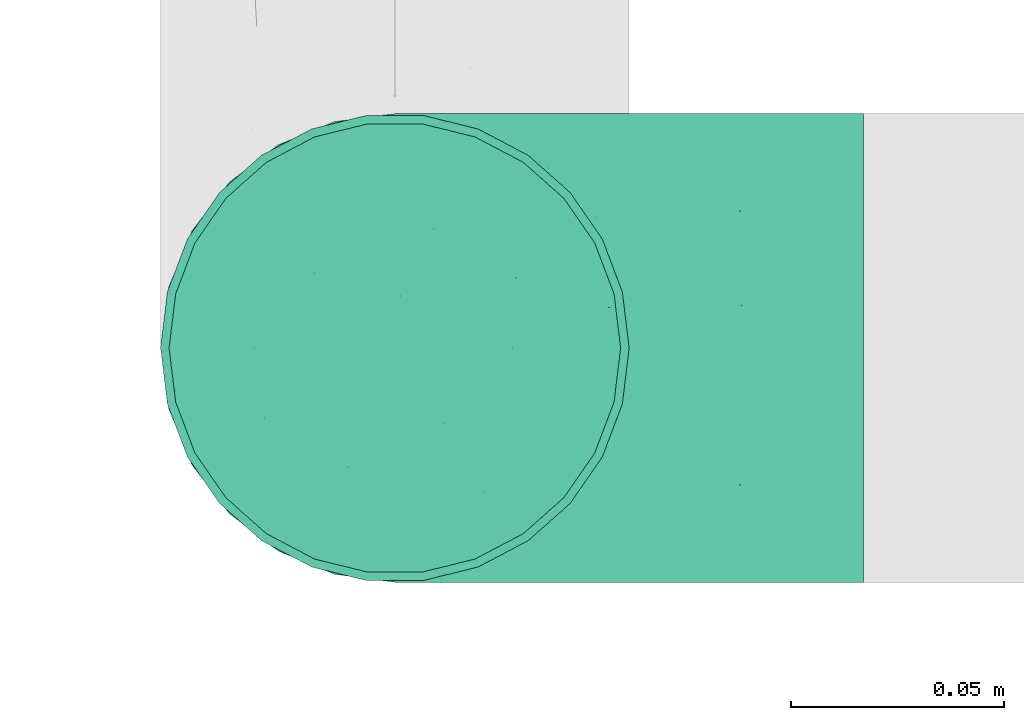
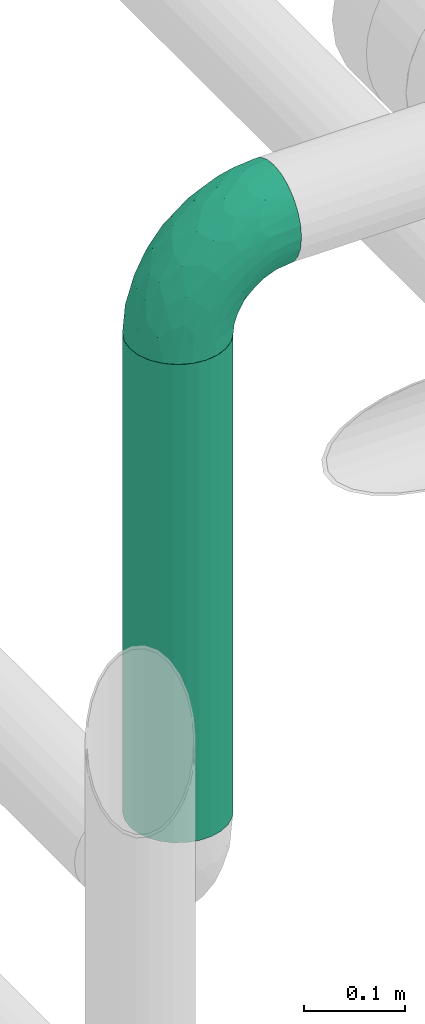
# One storey, part 41 of 91: 1 flow fitting, 1 flow segment.
"""IFC2X3 building model written with IfcOpenShell, lengths in millimetres."""

from ifc_helpers import new_model, entity, si_unit, converted_unit, derived_unit, direction, frame, origin_with_axes, origin_2d_with_axis, place, context, subcontext, project, spatial, hollow_circle, extrude, open_shell, surface_model, source, transform, mapped, material, layer, layer_set, layer_usage, type_object, element, save


model = new_model("IFC2X3")

# Units and contexts
model_context = context("Model", 3, precision=1e-05, world=origin_with_axes(), true_north=direction((0.0, 1.0)))
body_context = subcontext(model_context, "Body", "Model", "MODEL_VIEW")
ifc_project = project(units=[si_unit("AREAUNIT", "SQUARE_METRE"), si_unit("VOLUMEUNIT", "CUBIC_METRE", prefix="DECI"), si_unit("TIMEUNIT", "SECOND"), si_unit("THERMODYNAMICTEMPERATUREUNIT", "DEGREE_CELSIUS"), si_unit("PRESSUREUNIT", "PASCAL"), si_unit("MASSUNIT", "GRAM", prefix="KILO"), si_unit("LENGTHUNIT", "METRE", prefix="MILLI"), si_unit("POWERUNIT", "WATT"), si_unit("ELECTRICCURRENTUNIT", "AMPERE"), si_unit("ELECTRICVOLTAGEUNIT", "VOLT"), derived_unit("VOLUMETRICFLOWRATEUNIT", [(si_unit("VOLUMEUNIT", "CUBIC_METRE", prefix="DECI"), 1), (si_unit("TIMEUNIT", "SECOND"), -1)]), derived_unit("LINEARVELOCITYUNIT", [(si_unit("LENGTHUNIT", "METRE"), 1), (si_unit("TIMEUNIT", "SECOND"), -1)]), derived_unit("MASSDENSITYUNIT", [(si_unit("MASSUNIT", "GRAM", prefix="KILO"), 1), (si_unit("VOLUMEUNIT", "CUBIC_METRE"), -1)]), converted_unit("PLANEANGLEUNIT", "DEGREE", entity("IfcRatioMeasure", 0.01745), si_unit("PLANEANGLEUNIT", "RADIAN"), dimensions=[0, 0, 0, 0, 0, 0, 0])], contexts=[model_context])

# Site, building, storey
site_placement = place(None, origin_with_axes())
site = spatial("IfcSite", under=ifc_project, at=site_placement, CompositionType="ELEMENT")
building_placement = place(site_placement, origin_with_axes())
building = spatial("IfcBuilding", under=site, at=building_placement, Name="mc-building", CompositionType="ELEMENT")
storey_placement = place(building_placement, frame((0.0, 0.0, 8700.0), z_axis=(0.0, 0.0, 1.0), x_axis=(1.0, 0.0, 0.0)))
storey = spatial("IfcBuildingStorey", under=building, at=storey_placement, CompositionType="ELEMENT", Elevation=8700.0)

# Flow segment
ifc_material = material(Name="FZ1")
ifc_layer = layer(ifc_material, 0.0)
ifc_layer_set = layer_set([ifc_layer], Name="FZ1")
ifc_layer_usage = layer_usage(ifc_layer_set, "AXIS1", "POSITIVE", 0.0)
duct_segment_type = type_object("IfcDuctSegmentType", PredefinedType="RIGIDSEGMENT")
shared_shape_1 = source(origin_with_axes(), body_context, "Body", "SweptSolid", [
    extrude(hollow_circle(Radius=55.0, WallThickness=2.0, at=origin_2d_with_axis()), frame((0.0, 0.0, 0.0), z_axis=(1.0, 0.0, 0.0), x_axis=(0.0, 1.0, 0.0)), (0.0, 0.0, 1.0), 579.3),
])
flow_segment_placement = place(storey_placement, frame((7969.21808, 10596.38741, 1104.30701), z_axis=(0.0, 1.0, 0.0), x_axis=(0.0, 0.0, -1.0)))
element("IfcFlowSegment", 1, at=flow_segment_placement, inside=storey, type_object=duct_segment_type, material=ifc_layer_usage, context=body_context, shape_type="MappedRepresentation", body=[
    mapped(shared_shape_1, transform((0.0, 0.0, 0.0), scale=1.0)),
])

# Flow fitting
duct_fitting_type = type_object("IfcDuctFittingType", Name="BU", PredefinedType="BEND")
shared_shape_2 = source(origin_with_axes(), body_context, "Body", "SurfaceModel", [
    surface_model("IfcShellBasedSurfaceModel", [(-110.0, 0.0, -55.0), (-110.0, -14.23505, -53.12592), (-110.0, 14.23505, -53.12592), (-110.0, 53.12592, 14.23505), (-110.0, 27.5, -47.63139), (-110.0, 38.89087, -38.89087), (-110.0, -55.0, 0.0), (-110.0, -53.12592, 14.23505), (-110.0, -38.89087, -38.89087), (-110.0, -27.5, -47.63139), (-110.0, -53.12592, -14.23505), (-110.0, -47.63139, -27.5), (-110.0, -14.23505, 53.12592), (-110.0, 14.23505, 53.12592), (-110.0, 27.5, 47.63139), (-110.0, -47.63139, 27.5), (-110.0, -38.89087, 38.89087), (-110.0, -27.5, 47.63139), (-110.0, 0.0, 55.0), (-110.0, 55.0, 0.0), (-110.0, 53.12592, -14.23505), (-110.0, 47.63139, -27.5), (-110.0, 47.63139, 27.5), (-110.0, 38.89087, 38.89087), (-14.23505, 110.0, -53.12592), (-55.0, 110.0, 0.0), (0.0, 110.0, -55.0), (-27.5, 110.0, -47.63139), (-38.89087, 110.0, -38.89087), (-47.63139, 110.0, -27.5), (38.89087, 110.0, -38.89087), (53.12592, 110.0, 14.23505), (27.5, 110.0, -47.63139), (14.23505, 110.0, -53.12592), (47.63139, 110.0, -27.5), (53.12592, 110.0, -14.23505), (55.0, 110.0, 0.0), (-53.12592, 110.0, -14.23505), (-53.12592, 110.0, 14.23505), (-47.63139, 110.0, 27.5), (-38.89087, 110.0, 38.89087), (-27.5, 110.0, 47.63139), (0.0, 110.0, 55.0), (-14.23505, 110.0, 53.12592), (38.89087, 110.0, 38.89087), (47.63139, 110.0, 27.5), (27.5, 110.0, 47.63139), (14.23505, 110.0, 53.12592), (-64.21732, 48.68956, 43.63444), (-76.6405, 38.18013, 45.55988), (-60.44912, 32.56953, 51.94617), (-76.00813, 5.38378, 55.0), (-90.15553, 11.94394, 54.09138), (-78.5998, 26.77405, 50.81338), (-70.18771, 18.55163, 54.03432), (-75.55424, 54.2118, 32.41257), (-93.27622, 45.77614, 33.48188), (-96.12334, 22.13664, 50.81337), (-21.00813, 45.34362, 55.0), (-18.36258, 70.48427, 54.04484), (-32.04182, 59.64019, 52.24446), (-63.88653, 74.77858, 17.99134), (-74.66383, 63.08407, 19.92123), (-63.60674, 66.07878, 29.97482), (-99.597, 52.72185, 18.52927), (-93.11138, 56.59448, 10.50359), (-98.21577, 57.34403, 0.0), (-53.42855, 92.60092, 21.04759), (-88.54852, 54.8376, 21.04759), (-11.86161, 90.23965, 54.10313), (-5.38378, 76.00813, 55.0), (-57.34403, 98.21577, 0.0), (-56.64619, 93.12774, 10.22088), (-45.34362, 21.00813, 55.0), (-44.60838, 44.60838, 52.13415), (-92.68484, 35.46673, 43.63443), (-22.25266, 95.40765, 50.81337), (-35.97783, 90.61597, 43.63443), (-43.70931, 69.58671, 44.47149), (-27.23711, 77.39884, 50.81337), (-57.2828, 79.3123, 24.9774), (-58.67786, 84.31125, 16.04456), (-82.93277, 60.36161, 12.91784), (-49.88337, 54.51816, 47.224), (-74.57753, 66.83759, 9.55742), (-45.35812, 94.97281, 33.48188), (-59.18663, 88.95241, 0.0), (-51.517, 78.6292, 33.48188), (-65.14788, 80.03077, 0.0), (-56.45322, 62.06476, 39.63545), (-88.95241, 59.18663, 0.0), (-71.10913, 71.10913, 0.0), (-80.03077, 65.14788, 0.0), (-94.9309, 45.36788, -33.48188), (-93.11358, 56.60141, -10.46614), (-99.64997, 52.79499, -18.30015), (-90.20425, 36.08686, -43.63443), (-79.99933, 46.56772, -37.92748), (-76.00813, 5.38378, -55.0), (-72.75364, 19.68651, -53.60527), (-45.34362, 21.00813, -55.0), (-21.91957, 65.12078, -53.85897), (-5.38378, 76.00813, -55.0), (-21.00813, 45.34362, -55.0), (-35.41876, 92.89265, -43.63443), (-91.10309, 11.02766, -54.21832), (-45.77614, 93.27622, -33.48188), (-90.50474, 23.21022, -50.81337), (-70.92854, 33.31794, -49.51754), (-78.52933, 63.35627, -11.73997), (-24.91508, 84.05606, -50.81337), (-88.78941, 54.74452, -21.04759), (-69.59921, 57.34866, -33.48187), (-73.36422, 62.46673, -22.94182), (-63.49062, 67.59111, -28.46929), (-56.59448, 93.11138, -10.50359), (-54.8376, 88.54852, -21.04759), (-54.10679, 75.85581, -32.31867), (-57.75956, 31.09612, -52.80882), (-52.72185, 99.597, -18.52927), (-12.62913, 89.46304, -53.99097), (-34.46825, 66.46123, -50.04329), (-43.9837, 43.9837, -52.42279), (-65.78527, 72.58348, -17.68796), (-70.34468, 43.65295, -44.21951), (-57.47001, 51.99467, -44.91465), (-60.72547, 82.29174, -12.88567), (-42.34915, 74.24548, -43.63444), (-57.25194, 63.5016, -38.08211), (-80.95344, 53.56991, -29.32027), (-52.32891, 4.55257, -54.0482), (32.52942, 47.13398, -30.48571), (14.88266, 20.92917, -33.7947), (14.95561, 36.05775, -42.26543), (30.24048, 70.09027, -41.7461), (19.3559, 65.35825, -48.00507), (-70.35075, -46.44478, -19.5952), (-47.13398, -32.52942, -30.48571), (-28.49299, -30.5778, -16.4009), (-4.55257, 52.32891, -54.0482), (-22.4954, 22.4954, -53.25347), (-75.47368, -11.22546, -52.60718), (-81.32209, -51.5606, -9.98467), (-80.81763, -41.84862, -32.14655), (-70.09027, -30.24048, -41.7461), (-36.05774, -14.95561, -42.26543), (-9.15831, -10.852, -27.8997), (-65.35825, -19.3559, -48.00507), (11.22546, 75.47368, -52.60718), (3.94376, 43.9333, -50.53315), (-13.39742, 13.39743, -48.13058), (-43.9333, -3.94376, -50.53315), (49.37776, 67.29486, 0.0), (41.8609, 47.82256, -9.92641), (50.20582, 74.51695, -9.9731), (18.93131, 11.7156, -17.56239), (-27.5, -32.89419, 0.0), (-1.23348, -12.25375, -12.18106), (41.84862, 80.81763, -32.14655), (35.70604, 41.31408, -20.38235), (46.44478, 70.35075, -19.5952), (32.89419, 27.5, 0.0), (6.67262, -6.67262, 0.0), (-67.29486, -49.37776, 0.0), (-50.36265, -42.95545, -9.51562), (-5.47251, 5.47251, -39.92906), (-70.35075, -46.44478, 19.5952), (-74.51695, -50.20582, 9.9731), (-41.31407, -35.70604, 20.38235), (-47.13398, -32.52942, 30.48571), (-80.81763, -41.84862, 32.14655), (-4.55257, 52.32891, 54.0482), (11.22546, 75.47368, 52.60718), (-43.9333, -3.94376, 50.53315), (-65.35825, -19.3559, 48.00507), (-36.05774, -14.95561, 42.26543), (-70.09027, -30.24048, 41.7461), (-11.7156, -18.93131, 17.56239), (30.5778, 28.49299, 16.4009), (12.25375, 1.23348, 12.18106), (51.5606, 81.32209, 9.98467), (42.95545, 50.36265, 9.51562), (-75.47368, -11.22546, 52.60718), (-52.32891, 4.55257, 54.0482), (3.94376, 43.9333, 50.53315), (-22.4954, 22.4954, 53.25347), (-13.39742, 13.39743, 48.13058), (10.852, 9.15831, 27.8997), (-20.92916, -14.88266, 33.79469), (-47.82256, -41.8609, 9.92641), (32.52942, 47.13398, 30.48571), (46.44478, 70.35075, 19.5952), (41.84862, 80.81763, 32.14655), (30.24048, 70.09027, 41.7461), (19.3559, 65.35825, 48.00507), (14.95561, 36.05775, 42.26543), (-5.47251, 5.47251, 39.92906)], [open_shell([[[0, 1, 2]], [[2, 3, 4]], [[4, 3, 5]], [[2, 6, 7]], [[8, 6, 9]], [[1, 9, 6]], [[10, 6, 11]], [[8, 11, 6]], [[6, 2, 1]], [[12, 13, 14]], [[15, 2, 7]], [[16, 17, 2]], [[2, 17, 12]], [[12, 18, 13]], [[19, 20, 3]], [[5, 3, 21]], [[20, 21, 3]], [[22, 3, 2]], [[23, 22, 2]], [[12, 14, 2]], [[2, 14, 23]], [[15, 16, 2]], [[24, 25, 26]], [[27, 25, 24]], [[25, 28, 29]], [[28, 25, 27]], [[30, 26, 31]], [[26, 30, 32]], [[32, 33, 26]], [[34, 31, 35]], [[31, 34, 30]], [[35, 31, 36]], [[29, 37, 25]], [[38, 39, 26]], [[39, 40, 26]], [[41, 42, 40]], [[42, 26, 40]], [[42, 41, 43]], [[26, 44, 45]], [[31, 26, 45]], [[26, 46, 44]], [[47, 46, 26]], [[42, 47, 26]], [[25, 38, 26]], [[48, 49, 50]], [[18, 51, 52]], [[53, 54, 50]], [[55, 56, 49]], [[56, 22, 23]], [[13, 57, 14]], [[58, 59, 60]], [[61, 62, 63]], [[3, 64, 65]], [[53, 52, 54]], [[3, 65, 66]], [[67, 39, 38]], [[56, 68, 64]], [[65, 64, 68]], [[69, 59, 70]], [[38, 71, 72]], [[73, 58, 74]], [[75, 49, 56]], [[76, 69, 43]], [[53, 57, 52]], [[77, 78, 79]], [[41, 76, 43]], [[43, 69, 42]], [[55, 68, 56]], [[23, 14, 75]], [[76, 77, 79]], [[80, 67, 81]], [[62, 82, 68]], [[60, 78, 83]], [[62, 84, 82]], [[85, 77, 40]], [[81, 67, 72]], [[86, 72, 71]], [[87, 85, 67]], [[61, 81, 88]], [[77, 41, 40]], [[78, 77, 87]], [[23, 75, 56]], [[83, 89, 48]], [[85, 40, 39]], [[62, 68, 55]], [[89, 87, 63]], [[83, 48, 50]], [[57, 75, 14]], [[49, 75, 53]], [[67, 85, 39]], [[87, 77, 85]], [[63, 62, 55]], [[89, 55, 48]], [[80, 63, 87]], [[66, 65, 90]], [[66, 19, 3]], [[84, 91, 92]], [[92, 90, 82]], [[65, 82, 90]], [[61, 84, 62]], [[92, 82, 84]], [[68, 82, 65]], [[3, 22, 64]], [[56, 64, 22]], [[38, 25, 71]], [[81, 72, 86]], [[38, 72, 67]], [[91, 61, 88]], [[80, 81, 61]], [[63, 80, 61]], [[67, 80, 87]], [[77, 76, 41]], [[79, 59, 69]], [[79, 69, 76]], [[42, 69, 70]], [[60, 59, 79]], [[58, 70, 59]], [[78, 60, 79]], [[58, 60, 74]], [[52, 57, 13]], [[75, 57, 53]], [[18, 52, 13]], [[52, 51, 54]], [[51, 73, 54]], [[50, 73, 74]], [[73, 50, 54]], [[50, 74, 83]], [[60, 83, 74]], [[89, 83, 78]], [[87, 89, 78]], [[55, 89, 63]], [[50, 49, 53]], [[55, 49, 48]], [[81, 86, 88]], [[91, 84, 61]], [[5, 21, 93]], [[90, 94, 66]], [[20, 94, 95]], [[96, 93, 97]], [[98, 99, 100]], [[96, 4, 5]], [[101, 102, 103]], [[28, 27, 104]], [[2, 105, 0]], [[104, 106, 28]], [[99, 105, 107]], [[108, 107, 96]], [[90, 109, 94]], [[107, 2, 4]], [[20, 66, 94]], [[27, 24, 110]], [[109, 111, 94]], [[112, 113, 114]], [[37, 115, 71]], [[116, 106, 117]], [[99, 118, 100]], [[116, 115, 119]], [[37, 119, 115]], [[24, 120, 110]], [[121, 110, 101]], [[119, 106, 116]], [[101, 110, 120]], [[122, 103, 100]], [[117, 123, 116]], [[124, 125, 108]], [[115, 116, 126]], [[106, 29, 28]], [[26, 102, 120]], [[127, 104, 110]], [[97, 124, 96]], [[125, 122, 118]], [[128, 127, 125]], [[96, 5, 93]], [[115, 126, 86]], [[117, 106, 127]], [[111, 113, 129]], [[95, 93, 21]], [[97, 129, 112]], [[110, 104, 27]], [[106, 104, 127]], [[96, 107, 4]], [[99, 107, 108]], [[99, 108, 118]], [[105, 99, 98]], [[112, 114, 128]], [[121, 125, 127]], [[20, 19, 66]], [[109, 90, 92]], [[94, 111, 95]], [[91, 123, 109]], [[129, 113, 112]], [[93, 95, 111]], [[21, 20, 95]], [[71, 115, 86]], [[71, 25, 37]], [[123, 91, 88]], [[126, 116, 123]], [[123, 88, 126]], [[86, 126, 88]], [[37, 29, 119]], [[106, 119, 29]], [[129, 93, 111]], [[124, 112, 125]], [[0, 105, 98]], [[107, 105, 2]], [[125, 118, 108]], [[100, 118, 122]], [[93, 129, 97]], [[113, 111, 109]], [[109, 123, 113]], [[114, 123, 117]], [[123, 114, 113]], [[128, 114, 117]], [[127, 128, 117]], [[112, 128, 125]], [[103, 122, 101]], [[110, 121, 127]], [[101, 122, 121]], [[125, 121, 122]], [[26, 120, 24]], [[101, 120, 102]], [[96, 124, 108]], [[92, 91, 109]], [[112, 124, 97]], [[100, 130, 98]], [[131, 132, 133]], [[32, 134, 135]], [[136, 137, 138]], [[139, 140, 103]], [[98, 141, 0]], [[142, 10, 136]], [[143, 144, 137]], [[6, 10, 142]], [[137, 145, 146]], [[144, 147, 145]], [[143, 136, 11]], [[11, 136, 10]], [[8, 143, 11]], [[148, 149, 139]], [[8, 9, 144]], [[9, 1, 147]], [[130, 141, 98]], [[103, 140, 100]], [[148, 135, 149]], [[150, 151, 140]], [[152, 153, 154]], [[130, 140, 151]], [[148, 26, 33]], [[147, 1, 141]], [[155, 146, 132]], [[156, 138, 157]], [[134, 30, 158]], [[150, 140, 149]], [[158, 30, 34]], [[30, 134, 32]], [[153, 159, 160]], [[131, 160, 159]], [[144, 145, 137]], [[36, 152, 154]], [[146, 138, 137]], [[155, 161, 162]], [[158, 160, 131]], [[133, 149, 135]], [[156, 163, 164]], [[163, 142, 164]], [[139, 103, 102]], [[153, 152, 161]], [[34, 35, 160]], [[162, 157, 155]], [[132, 165, 133]], [[157, 146, 155]], [[140, 130, 100]], [[141, 130, 151]], [[141, 151, 147]], [[141, 1, 0]], [[102, 26, 148]], [[140, 139, 149]], [[102, 148, 139]], [[135, 33, 32]], [[151, 150, 145]], [[9, 147, 144]], [[151, 145, 147]], [[145, 165, 146]], [[135, 148, 33]], [[133, 135, 134]], [[131, 133, 134]], [[133, 165, 150]], [[133, 150, 149]], [[145, 150, 165]], [[132, 131, 159]], [[146, 165, 132]], [[160, 158, 34]], [[134, 158, 131]], [[144, 143, 8]], [[136, 143, 137]], [[155, 153, 161]], [[154, 153, 160]], [[153, 155, 159]], [[132, 159, 155]], [[160, 35, 154]], [[36, 154, 35]], [[164, 136, 138]], [[6, 142, 163]], [[136, 164, 142]], [[156, 164, 138]], [[156, 157, 162]], [[146, 157, 138]], [[15, 7, 166]], [[6, 163, 167]], [[168, 169, 166]], [[166, 169, 170]], [[171, 172, 70]], [[173, 174, 175]], [[17, 176, 174]], [[177, 156, 162]], [[176, 16, 170]], [[170, 16, 15]], [[161, 178, 179]], [[152, 180, 181]], [[182, 173, 183]], [[18, 12, 182]], [[184, 185, 186]], [[183, 185, 73]], [[183, 73, 51]], [[177, 187, 188]], [[189, 168, 166]], [[187, 178, 190]], [[16, 176, 17]], [[161, 152, 181]], [[45, 191, 31]], [[45, 44, 192]], [[192, 191, 45]], [[180, 36, 31]], [[193, 194, 195]], [[46, 47, 194]], [[193, 195, 190]], [[193, 44, 46]], [[172, 42, 70]], [[185, 58, 73]], [[189, 163, 156]], [[163, 189, 167]], [[70, 58, 171]], [[184, 171, 185]], [[169, 188, 175]], [[180, 31, 191]], [[192, 193, 190]], [[191, 190, 178]], [[182, 174, 173]], [[194, 47, 172]], [[190, 195, 187]], [[186, 185, 173]], [[162, 179, 177]], [[188, 196, 175]], [[179, 187, 177]], [[185, 171, 58]], [[172, 171, 184]], [[172, 184, 194]], [[172, 47, 42]], [[51, 18, 182]], [[185, 183, 173]], [[51, 182, 183]], [[174, 12, 17]], [[184, 186, 195]], [[46, 194, 193]], [[184, 195, 194]], [[195, 196, 187]], [[174, 182, 12]], [[175, 174, 176]], [[169, 175, 176]], [[175, 196, 186]], [[175, 186, 173]], [[195, 186, 196]], [[188, 169, 168]], [[187, 196, 188]], [[166, 170, 15]], [[176, 170, 169]], [[193, 192, 44]], [[191, 192, 190]], [[177, 189, 156]], [[167, 189, 166]], [[189, 177, 168]], [[188, 168, 177]], [[166, 7, 167]], [[6, 167, 7]], [[181, 191, 178]], [[36, 180, 152]], [[191, 181, 180]], [[161, 181, 178]], [[161, 179, 162]], [[187, 179, 178]]])]),
])
flow_fitting_placement = place(storey_placement, frame((7969.21808, 10596.38741, 1214.30701), z_axis=(0.0, 1.0, 0.0), x_axis=(0.0, 0.0, 1.0)))
element("IfcFlowFitting", 2, at=flow_fitting_placement, inside=storey, type_object=duct_fitting_type, Name="BU", context=body_context, shape_type="MappedRepresentation", body=[
    mapped(shared_shape_2, transform((0.0, 0.0, 0.0), scale=1.0)),
])

save(model, "model.ifc")
